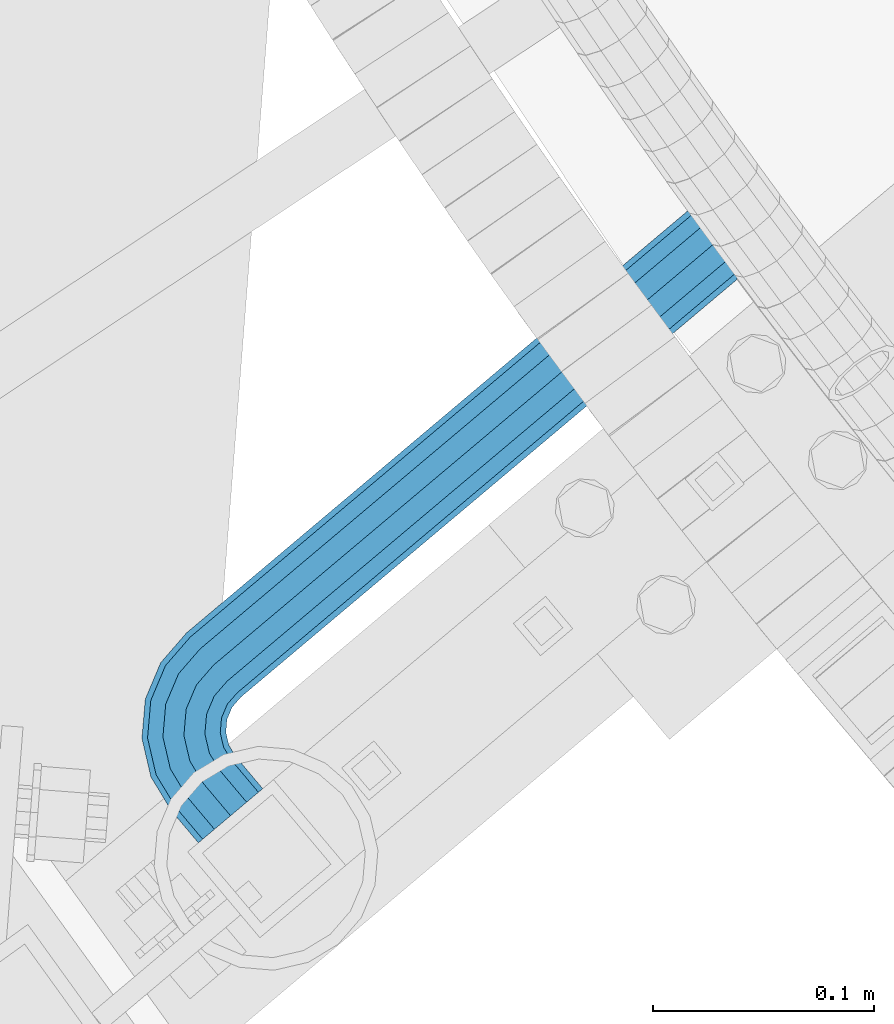
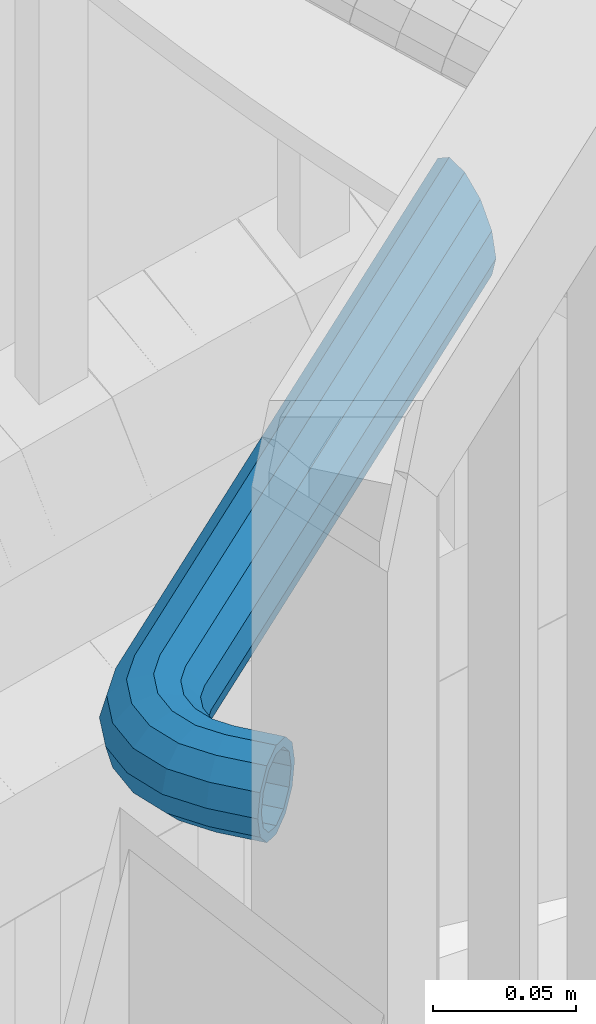
# One storey, part 462 of 975: 1 beam.
"""IFC2X3 building model written with IfcOpenShell, lengths in millimetres."""

from ifc_helpers import new_model, si_unit, frame, origin_with_axes, place, context, subcontext, project, spatial, faceted_brep, material, type_object, element, save


model = new_model("IFC2X3")

# Units and contexts
model_context = context("Model", 3, precision=1e-05, world=origin_with_axes())
body_context = subcontext(model_context, "Body", "Model", "MODEL_VIEW")
ifc_project = project(units=[si_unit("LENGTHUNIT", "METRE", prefix="MILLI"), si_unit("AREAUNIT", "SQUARE_METRE"), si_unit("VOLUMEUNIT", "CUBIC_METRE"), si_unit("MASSUNIT", "GRAM", prefix="KILO"), si_unit("TIMEUNIT", "SECOND"), si_unit("PLANEANGLEUNIT", "RADIAN"), si_unit("SOLIDANGLEUNIT", "STERADIAN"), si_unit("THERMODYNAMICTEMPERATUREUNIT", "DEGREE_CELSIUS"), si_unit("LUMINOUSINTENSITYUNIT", "LUMEN")], contexts=[model_context])

# Site, building, storey
site_placement = place(None, origin_with_axes())
site = spatial("IfcSite", under=ifc_project, at=site_placement, CompositionType="ELEMENT")
building_placement = place(site_placement, origin_with_axes())
building = spatial("IfcBuilding", under=site, at=building_placement, Name="Undefined", CompositionType="ELEMENT")
storey_placement = place(building_placement, origin_with_axes())
storey = spatial("IfcBuildingStorey", under=building, at=storey_placement, Name="Undefined", CompositionType="ELEMENT", Elevation=0.0)

# Beam
ifc_material = material()
beam_type = type_object("IfcBeamType", PredefinedType="NOTDEFINED")
beam_placement = place(storey_placement, frame((32253.5605564265, 1485.20133576111, 4984.75), z_axis=(0.0, 0.0, 1.0), x_axis=(-0.644003592002054, 0.765022466002438, 0.0)))
element("IfcBeam", 1, at=beam_placement, inside=storey, type_object=beam_type, material=ifc_material, Name="HANDRAIL", context=body_context, shape_type="Brep", body=[
    faceted_brep([(-2.28097633225843e-07, -16.4977839420972, -9.52499999999964), (-1.31691194837913e-07, -9.52500000000146, -16.4977839420935), (19.049996278598, -9.52500026337293, -16.4977839420935), (19.0499961821952, -16.4977842054686, -9.52499999999964), (-3.63797880709171e-12, 3.63797880709171e-12, -19.0500000000002), (19.0499964102855, -2.63371475739405e-07, -19.0500000000002), (1.31687556859106e-07, 9.52500000000509, -16.4977839420935), (19.0499965419804, 9.52499973663362, -16.4977839420935), (2.28097633225843e-07, 16.4977839421044, -9.52499999999964), (19.0499966383868, 16.4977836787293, -9.52499999999964), (2.63382389675826e-07, 19.0500000000138, 0.0), (19.0499966736716, 19.0499997366351, 0.0), (2.28097633225843e-07, 16.4977839421044, 9.52499999999964), (19.0499966383868, 16.4977836787293, 9.52499999999964), (1.31687556859106e-07, 9.52500000000509, 16.4977839420935), (19.0499965419804, 9.52499973663362, 16.4977839420935), (-3.63797880709171e-12, 3.63797880709171e-12, 19.0500000000002), (19.0499964102855, -2.63371475739405e-07, 19.0500000000002), (-1.31691194837913e-07, -9.52500000000146, 16.4977839420935), (19.049996278598, -9.52500026337293, 16.4977839420935), (-2.28097633225843e-07, -16.4977839420972, 9.52499999999964), (19.0499961821952, -16.4977842054686, 9.52499999999964), (-2.63386027654633e-07, -19.0500000000029, 0.0), (19.0499961469068, -19.0500002633744, 0.0), (24.9367694875691, -19.9823736613762, 0.0), (25.7254476673588, -17.5550719629973, 9.52499999999964), (27.8801565253561, -10.9235603977177, 16.4977839420935), (30.8235435631395, -1.86474713405551, 19.0500000000002), (33.7669306009229, 7.19406612960302, 16.4977839420935), (35.9216394589203, 13.8255776948827, 9.52499999999964), (36.7103176387063, 16.2528793932652, 0.0), (35.9216394589203, 13.8255776948827, -9.52499999999964), (33.7669306009229, 7.19406612960302, -16.4977839420935), (30.8235435631395, -1.86474713405551, -19.0500000000002), (27.8801565253561, -10.9235603977177, -16.4977839420935), (25.7254476673588, -17.5550719629973, -9.52499999999964), (57.1499943576491, -38.1000001288958, -19.0500000000002), (66.6749943576469, -38.1000004767448, -16.4977839420935), (66.6749825162733, -362.343518226528, -16.4977839420935), (57.1499828883207, -352.155925105868, -19.0500000000002), (47.6249943576477, -38.0999997810504, -16.4977839420935), (47.6249832603717, -341.968331985212, -16.4977839420935), (40.652210415552, -38.0999995264065, -9.52499999999964), (40.6521995906369, -334.51049621405, -9.52499999999964), (38.0999943576462, -38.0999994332014, 0.0), (38.0999836324227, -331.780738864552, 0.0), (40.652210415552, -38.0999995264065, 9.52499999999964), (40.6521995906369, -334.51049621405, 9.52499999999964), (47.6249943576477, -38.0999997810504, 16.4977839420935), (47.6249832603717, -341.968331985212, 16.4977839420935), (57.1499943576491, -38.1000001288958, 19.0500000000002), (57.1499828883207, -352.155925105868, 19.0500000000002), (66.6749943576469, -38.1000004767448, 16.4977839420935), (66.6749825162733, -362.343518226528, 16.4977839420935), (73.6477782997426, -38.1000007313887, 9.52499999999964), (73.6477661860081, -369.801353997689, 9.52499999999964), (76.1999943576484, -38.1000008245937, 0.0), (76.1999821442223, -372.531111347187, 0.0), (73.6477782997426, -38.1000007313887, -9.52499999999964), (73.6477661860081, -369.801353997689, -9.52499999999964), (70.9755731653058, -21.2283577763119, -9.52499999999964), (64.3440614915489, -23.383066300441, -16.4977839420935), (73.4028749033932, -20.4396797187292, 0.0), (70.9755731653058, -21.2283577763119, 9.52499999999964), (64.3440614915489, -23.383066300441, 16.4977839420935), (55.2852480797046, -26.3264528821601, 19.0500000000002), (46.2264346678603, -29.2698394638792, 16.4977839420935), (39.5949229941034, -31.4245479880119, 9.52499999999964), (37.167621256016, -32.213226045591, 0.0), (39.5949229941034, -31.4245479880119, -9.52499999999964), (46.2264346678603, -29.2698394638792, -16.4977839420935), (55.2852480797046, -26.3264528821601, -19.0500000000002), (57.5794297743705, -10.1067280512689, -16.4977839420935), (49.8735427493084, -15.7053823678943, -19.0500000000002), (63.2205305941025, -6.00822863748544, -9.52499999999964), (65.2853167994326, -4.50807373465068, 0.0), (63.2205305941025, -6.00822863748544, 9.52499999999964), (57.5794297743705, -10.1067280512689, 16.4977839420935), (49.8735427493084, -15.7053823678943, 19.0500000000002), (42.1676557242463, -21.3040366845198, 16.4977839420935), (36.526554904518, -25.4025360983032, 9.52499999999964), (34.4617686991842, -26.9026910011453, 0.0), (36.526554904518, -25.4025360983032, -9.52499999999964), (42.1676557242463, -21.3040366845198, -16.4977839420935), (41.4446138049461, -7.2764529991764, -19.0500000000002), (35.8459591003702, -14.9823397423716, -16.4977839420935), (47.0432685095257, 0.42943374402239, -16.4977839420935), (51.1417682073115, 6.07053435741182, -9.52499999999964), (52.6419232141016, 8.13532048722118, 0.0), (51.1417682073115, 6.07053435741182, 9.52499999999964), (47.0432685095257, 0.42943374402239, 16.4977839420935), (41.4446138049461, -7.2764529991764, 19.0500000000002), (35.8459591003702, -14.9823397423716, 16.4977839420935), (31.7474594025807, -20.6234403557646, 9.52499999999964), (30.2473043957907, -22.6882264855703, 0.0), (31.7474594025807, -20.6234403557646, -9.52499999999964), (-1.83998054126278e-07, -13.3082123799541, -7.68350000000009), (-1.06232619145885e-07, -7.68349999999919, -13.3082123799559), (-3.63797880709171e-12, 3.63797880709171e-12, -15.3670000000002), (1.06225343188271e-07, 7.68350000000646, -13.3082123799559), (1.8399441614747e-07, 13.308212379965, -7.68350000000009), (2.12461600312963e-07, 15.3670000000093, 0.0), (1.8399441614747e-07, 13.308212379965, 7.68350000000009), (1.06225343188271e-07, 7.68350000000646, 13.3082123799559), (-3.63797880709171e-12, 3.63797880709171e-12, 15.3670000000002), (-1.06232619145885e-07, -7.68349999999919, 13.3082123799559), (-1.83998054126278e-07, -13.3082123799541, 7.68350000000009), (-2.1246523829177e-07, -15.367000000002, 0.0), (19.0499965165218, 7.68349973663135, -13.3082123799559), (19.0499965942836, 13.3082121165862, -7.68350000000009), (19.0499966227508, 15.3669997366342, 0.0), (19.0499965942836, 13.3082121165862, 7.68350000000009), (19.0499965165218, 7.68349973663135, 13.3082123799559), (19.0499964102855, -2.63371475739405e-07, 15.3670000000002), (19.0499963040565, -7.6835002633743, 13.3082123799559), (19.0499962262911, -13.3082126433328, 7.68350000000009), (19.0499961978276, -15.3670002633735, 0.0), (19.0499962262911, -13.3082126433328, -7.68350000000009), (19.0499963040565, -7.6835002633743, -13.3082123799559), (19.0499964102855, -2.63371475739405e-07, -15.3670000000002), (30.8235435631395, -1.86474713405551, -15.3670000000002), (33.1978757736179, 5.44269556529616, -13.3082123799559), (34.9360075857367, 10.7921148946225, -7.68350000000009), (35.5722079840962, 12.7501382646478, 0.0), (34.9360075857367, 10.7921148946225, 7.68350000000009), (33.1978757736179, 5.44269556529616, 13.3082123799559), (30.8235435631395, -1.86474713405551, 15.3670000000002), (28.4492113526576, -9.17218983340717, 13.3082123799559), (26.7110795405388, -14.5216091627371, 7.68350000000009), (26.0748791421793, -16.4796325327625, 0.0), (26.7110795405388, -14.5216091627371, -7.68350000000009), (28.4492113526576, -9.17218983340717, -13.3082123799559), (36.9283656765874, -13.4925349720215, -13.3082123799559), (41.4446138049461, -7.2764529991764, -15.3670000000002), (33.6222425870401, -18.0430228001569, -7.68350000000009), (32.4121175482287, -19.7086169448667, 0.0), (33.6222425870401, -18.0430228001569, 7.68350000000009), (36.9283656765874, -13.4925349720215, 13.3082123799559), (41.4446138049461, -7.2764529991764, 15.3670000000002), (45.9608619333048, -1.06037102633127, 13.3082123799559), (49.2669850228522, 3.49011680180774, 7.68350000000009), (50.4771100616672, 5.1557109465175, 0.0), (49.2669850228522, 3.49011680180774, -7.68350000000009), (45.9608619333048, -1.06037102633127, -13.3082123799559), (49.8735427493084, -15.7053823678943, -15.3670000000002), (56.0896249495236, -11.1891345524855, -13.3082123799559), (43.6574605490932, -20.2216301833068, -13.3082123799559), (39.1069725545094, -23.5277530437597, -7.68350000000009), (37.4413783488744, -24.7378779987157, 0.0), (39.1069725545094, -23.5277530437597, 7.68350000000009), (43.6574605490932, -20.2216301833068, 13.3082123799559), (49.8735427493084, -15.7053823678943, 15.3670000000002), (56.0896249495236, -11.1891345524855, 13.3082123799559), (60.6401129441074, -7.88301169203623, 7.68350000000009), (62.3057071497424, -6.67288673707662, 0.0), (60.6401129441074, -7.88301169203623, -7.68350000000009), (62.5926908985894, -23.952121039576, -13.3082123799559), (67.9421103154236, -22.2139894967768, -7.68350000000009), (55.2852480797046, -26.3264528821601, -15.3670000000002), (47.9778052608162, -28.7007847247442, -13.3082123799559), (42.6283858439856, -30.4389162675434, -7.68350000000009), (40.6703624419279, -31.0751165673319, 0.0), (42.6283858439856, -30.4389162675434, 7.68350000000009), (47.9778052608162, -28.7007847247442, 13.3082123799559), (55.2852480797046, -26.3264528821601, 15.3670000000002), (62.5926908985894, -23.952121039576, 13.3082123799559), (67.9421103154236, -22.2139894967768, 7.68350000000009), (69.9001337174814, -21.5777891969883, 0.0), (70.4582067376032, -38.1000006149043, -7.68350000000009), (72.5169943576511, -38.1000006900904, 0.0), (64.8334943576483, -38.1000004094967, -13.3082123799559), (57.1499943576491, -38.1000001288958, -15.3670000000002), (49.4664943576463, -38.0999998483021, -13.3082123799559), (43.8417819776914, -38.0999996428873, -7.68350000000009), (41.7829943576471, -38.0999995676975, 0.0), (43.8417819776914, -38.0999996428873, 7.68350000000009), (49.4664943576463, -38.0999998483021, 13.3082123799559), (57.1499943576491, -38.1000001288958, 15.3670000000002), (64.8334943576483, -38.1000004094967, 13.3082123799559), (70.4582067376032, -38.1000006149043, 7.68350000000009), (72.5169822880816, -368.591908673869, 0.0), (70.4581947484548, -366.389904411939, 7.68350000000009), (64.8334825882012, -360.373916889865, 13.3082123799559), (57.1499828883207, -352.155925105868, 15.3670000000002), (49.4664831884438, -343.937933321868, 13.3082123799559), (43.8417710281901, -337.921945799801, 7.68350000000009), (41.7829834885633, -335.719941537871, 0.0), (43.8417710281901, -337.921945799801, -7.68350000000009), (49.4664831884438, -343.937933321868, -13.3082123799559), (57.1499828883207, -352.155925105868, -15.3670000000002), (64.8334825882012, -360.373916889865, -13.3082123799559), (70.4581947484548, -366.389904411939, -7.68350000000009)], [[[0, 1, 2, 3]], [[1, 4, 5, 2]], [[4, 6, 7, 5]], [[6, 8, 9, 7]], [[8, 10, 11, 9]], [[10, 12, 13, 11]], [[12, 14, 15, 13]], [[14, 16, 17, 15]], [[16, 18, 19, 17]], [[18, 20, 21, 19]], [[20, 22, 23, 21]], [[21, 23, 24, 25]], [[19, 21, 25, 26]], [[17, 19, 26, 27]], [[15, 17, 27, 28]], [[13, 15, 28, 29]], [[11, 13, 29, 30]], [[9, 11, 30, 31]], [[7, 9, 31, 32]], [[5, 7, 32, 33]], [[2, 5, 33, 34]], [[3, 2, 34, 35]], [[36, 37, 38, 39]], [[40, 36, 39, 41]], [[42, 40, 41, 43]], [[44, 42, 43, 45]], [[46, 44, 45, 47]], [[48, 46, 47, 49]], [[50, 48, 49, 51]], [[52, 50, 51, 53]], [[54, 52, 53, 55]], [[56, 54, 55, 57]], [[58, 56, 57, 59]], [[37, 58, 59, 38]], [[60, 58, 37, 61]], [[62, 56, 58, 60]], [[63, 54, 56, 62]], [[64, 52, 54, 63]], [[65, 50, 52, 64]], [[66, 48, 50, 65]], [[67, 46, 48, 66]], [[68, 44, 46, 67]], [[69, 42, 44, 68]], [[70, 40, 42, 69]], [[71, 36, 40, 70]], [[61, 37, 36, 71]], [[72, 61, 71, 73]], [[74, 60, 61, 72]], [[75, 62, 60, 74]], [[76, 63, 62, 75]], [[77, 64, 63, 76]], [[78, 65, 64, 77]], [[79, 66, 65, 78]], [[80, 67, 66, 79]], [[81, 68, 67, 80]], [[82, 69, 68, 81]], [[83, 70, 69, 82]], [[73, 71, 70, 83]], [[84, 73, 83, 85]], [[86, 72, 73, 84]], [[87, 74, 72, 86]], [[88, 75, 74, 87]], [[89, 76, 75, 88]], [[90, 77, 76, 89]], [[91, 78, 77, 90]], [[92, 79, 78, 91]], [[93, 80, 79, 92]], [[94, 81, 80, 93]], [[95, 82, 81, 94]], [[85, 83, 82, 95]], [[34, 85, 95, 35]], [[33, 84, 85, 34]], [[32, 86, 84, 33]], [[31, 87, 86, 32]], [[30, 88, 87, 31]], [[29, 89, 88, 30]], [[28, 90, 89, 29]], [[27, 91, 90, 28]], [[26, 92, 91, 27]], [[25, 93, 92, 26]], [[24, 94, 93, 25]], [[35, 95, 94, 24]], [[23, 3, 35, 24]], [[22, 0, 3, 23]], [[20, 18, 16, 14, 12, 10, 8, 6, 4, 1, 0, 22], [96, 97, 98, 99, 100, 101, 102, 103, 104, 105, 106, 107]], [[100, 99, 108, 109]], [[101, 100, 109, 110]], [[102, 101, 110, 111]], [[103, 102, 111, 112]], [[104, 103, 112, 113]], [[105, 104, 113, 114]], [[106, 105, 114, 115]], [[107, 106, 115, 116]], [[96, 107, 116, 117]], [[97, 96, 117, 118]], [[98, 97, 118, 119]], [[99, 98, 119, 108]], [[108, 119, 120, 121]], [[109, 108, 121, 122]], [[110, 109, 122, 123]], [[111, 110, 123, 124]], [[112, 111, 124, 125]], [[113, 112, 125, 126]], [[114, 113, 126, 127]], [[115, 114, 127, 128]], [[116, 115, 128, 129]], [[117, 116, 129, 130]], [[118, 117, 130, 131]], [[119, 118, 131, 120]], [[131, 132, 133, 120]], [[130, 134, 132, 131]], [[129, 135, 134, 130]], [[128, 136, 135, 129]], [[127, 137, 136, 128]], [[126, 138, 137, 127]], [[125, 139, 138, 126]], [[124, 140, 139, 125]], [[123, 141, 140, 124]], [[122, 142, 141, 123]], [[121, 143, 142, 122]], [[120, 133, 143, 121]], [[133, 144, 145, 143]], [[132, 146, 144, 133]], [[134, 147, 146, 132]], [[135, 148, 147, 134]], [[136, 149, 148, 135]], [[137, 150, 149, 136]], [[138, 151, 150, 137]], [[139, 152, 151, 138]], [[140, 153, 152, 139]], [[141, 154, 153, 140]], [[142, 155, 154, 141]], [[143, 145, 155, 142]], [[145, 156, 157, 155]], [[144, 158, 156, 145]], [[146, 159, 158, 144]], [[147, 160, 159, 146]], [[148, 161, 160, 147]], [[149, 162, 161, 148]], [[150, 163, 162, 149]], [[151, 164, 163, 150]], [[152, 165, 164, 151]], [[153, 166, 165, 152]], [[154, 167, 166, 153]], [[155, 157, 167, 154]], [[157, 168, 169, 167]], [[156, 170, 168, 157]], [[158, 171, 170, 156]], [[159, 172, 171, 158]], [[160, 173, 172, 159]], [[161, 174, 173, 160]], [[162, 175, 174, 161]], [[163, 176, 175, 162]], [[164, 177, 176, 163]], [[165, 178, 177, 164]], [[166, 179, 178, 165]], [[167, 169, 179, 166]], [[179, 169, 180, 181]], [[178, 179, 181, 182]], [[177, 178, 182, 183]], [[176, 177, 183, 184]], [[175, 176, 184, 185]], [[174, 175, 185, 186]], [[173, 174, 186, 187]], [[172, 173, 187, 188]], [[171, 172, 188, 189]], [[170, 171, 189, 190]], [[168, 170, 190, 191]], [[169, 168, 191, 180]], [[53, 51, 49, 47, 45, 43, 41, 39, 38, 59, 57, 55], [190, 189, 188, 187, 186, 185, 184, 183, 182, 181, 180, 191]]]),
])

save(model, "model.ifc")
